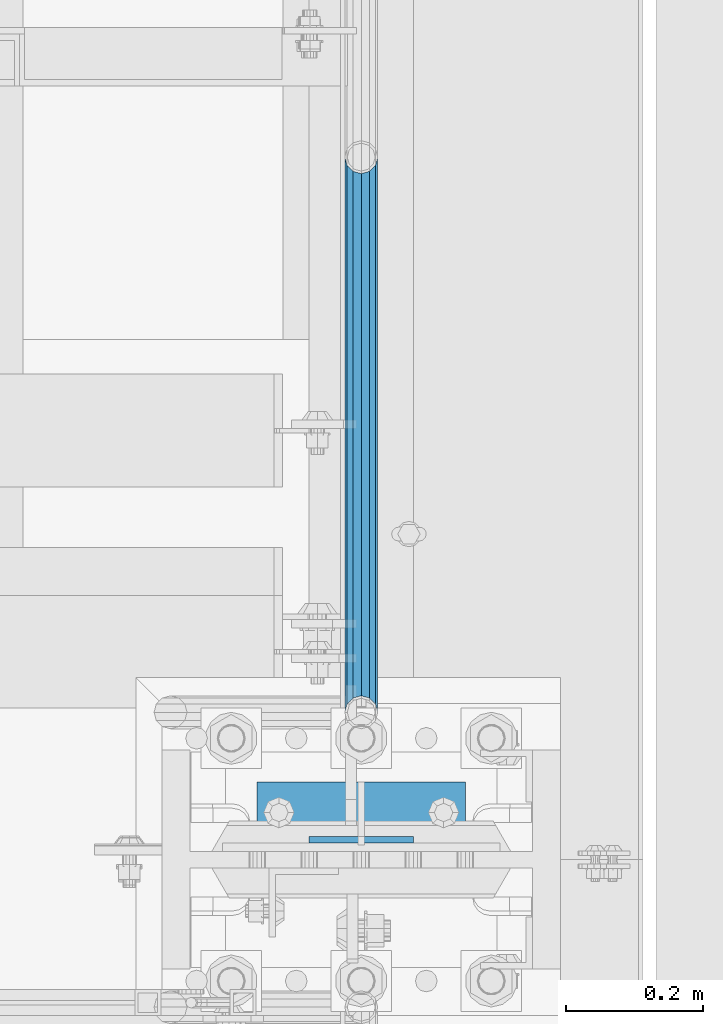
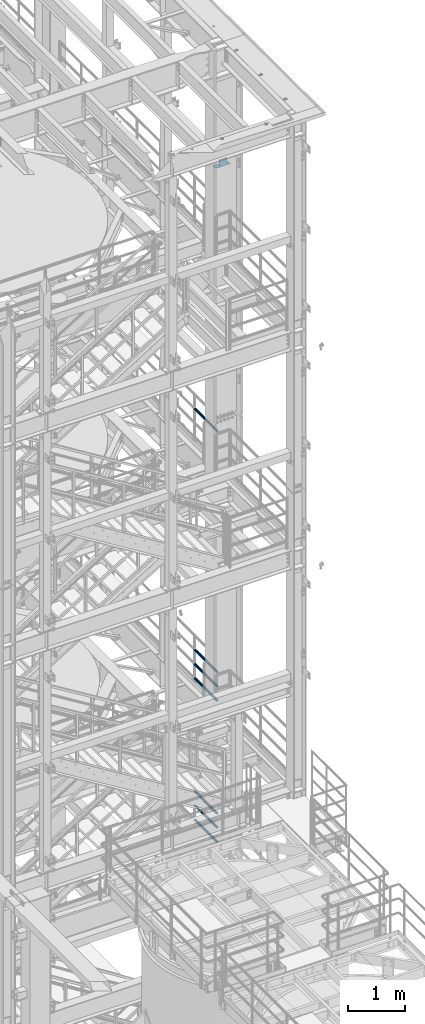
# One storey, part 1219 of 1876: 9 beams, 4 elements without a shape of their own.
"""IFC2X3 building model written with IfcOpenShell, lengths in millimetres."""

from ifc_helpers import new_model, si_unit, frame, origin_with_axes, place, context, subcontext, project, spatial, faceted_brep, material, type_object, element, aggregate, save


model = new_model("IFC2X3")

# Units and contexts
model_context = context("Model", 3, precision=1e-05, world=origin_with_axes())
body_context = subcontext(model_context, "Body", "Model", "MODEL_VIEW")
ifc_project = project(units=[si_unit("LENGTHUNIT", "METRE", prefix="MILLI"), si_unit("AREAUNIT", "SQUARE_METRE"), si_unit("VOLUMEUNIT", "CUBIC_METRE"), si_unit("MASSUNIT", "GRAM", prefix="KILO"), si_unit("TIMEUNIT", "SECOND"), si_unit("PLANEANGLEUNIT", "RADIAN"), si_unit("SOLIDANGLEUNIT", "STERADIAN"), si_unit("THERMODYNAMICTEMPERATUREUNIT", "DEGREE_CELSIUS"), si_unit("LUMINOUSINTENSITYUNIT", "LUMEN")], contexts=[model_context])

# Site, building, storey
site_placement = place(None, origin_with_axes())
site = spatial("IfcSite", under=ifc_project, at=site_placement, CompositionType="ELEMENT")
building_placement = place(site_placement, origin_with_axes())
building = spatial("IfcBuilding", under=site, at=building_placement, Name="Undefined", CompositionType="ELEMENT")
storey_placement = place(building_placement, origin_with_axes())
storey = spatial("IfcBuildingStorey", under=building, at=storey_placement, Name="Undefined", CompositionType="ELEMENT", Elevation=0.0)

# Assembly, beam
assembly_1_placement = place(storey_placement, origin_with_axes())
assembly_1 = element("IfcElementAssembly", 1, at=assembly_1_placement, inside=storey, Name="BEAM", AssemblyPlace="NOTDEFINED", PredefinedType="RIGID_FRAME")
ifc_material_1 = material(Name="STEEL/A36")
beam_type_1 = type_object("IfcBeamType", PredefinedType="NOTDEFINED")
beam_1_placement = place(assembly_1_placement, frame((7696.2, -4542.63125, 19958.05), z_axis=(0.0, 0.0, 1.0), x_axis=(-1.0, 0.0, 0.0)))
beam_1 = element("IfcBeam", 2, at=beam_1_placement, type_object=beam_type_1, material=ifc_material_1, Name="PLATE", context=body_context, shape_type="Brep", body=[
    faceted_brep([(0.0, 4.76249999999982, -76.1999999999998), (3.63797880709171e-12, 4.76249999999982, 76.1999969482422), (152.399993896484, 4.76250000000073, 76.1999969482422), (152.4, 4.76249999999982, -76.1999999999998), (3.63797880709171e-12, -4.76249999999982, 76.1999969482422), (152.399993896484, -4.76250000000073, 76.1999969482422), (0.0, -4.76249999999982, -76.1999999999998), (152.4, -4.76249999999982, -76.1999999999998)], [[[0, 1, 2, 3]], [[4, 5, 2, 1]], [[4, 6, 7, 5]], [[6, 0, 3, 7]], [[5, 7, 3, 2]], [[6, 4, 1, 0]]]),
])

assembly_2_placement = place(storey_placement, origin_with_axes())
assembly_2 = element("IfcElementAssembly", 3, at=assembly_2_placement, inside=storey, Name="RAIL", AssemblyPlace="NOTDEFINED", PredefinedType="RIGID_FRAME")
ifc_material_2 = material()
beam_type_2 = type_object("IfcBeamType", Name="PIPE1-1/2SCH40", PredefinedType="NOTDEFINED")
beam_2_placement = place(assembly_2_placement, frame((7620.00000000001, -4356.1, 14081.1250000359), z_axis=(0.0, 0.0, -1.0), x_axis=(0.0, 1.0, 0.0)))
beam_2 = element("IfcBeam", 4, at=beam_2_placement, type_object=beam_type_2, material=ifc_material_2, Name="RAIL", ObjectType="PIPE1-1/2SCH40", context=body_context, shape_type="Brep", body=[
    faceted_brep([(0.0, 24.1299999999992, 0.0), (12.0650000000064, 20.8971929933177, -12.0649999999987), (12.0650000000064, 20.8971929933177, 12.0649999999987), (12.0650000000064, -20.8971929933177, 12.0649999999987), (12.0650000000064, -20.8971929933177, -12.0649999999987), (0.0, -24.1299999999992, 0.0), (20.8971929933249, -12.0650000000005, 20.8971929933177), (20.8971929933249, -12.0650000000005, 15.8661214311796), (15.2545715621445, -17.7076214311801, 10.2235000000001), (12.5151929933249, -20.4470000000001, 0.0), (15.2545715621445, -17.7076214311801, -10.2235000000001), (20.8971929933249, -12.0650000000005, -15.8661214311796), (20.8971929933249, -12.0650000000005, -20.8971929933177), (24.1300000000063, 0.0, -20.4470000000001), (24.1300000000063, 0.0, -24.130000000001), (21.3906214311868, -10.2235000000001, -17.7076214311819), (21.3906214311868, 10.2235000000001, -17.7076214311819), (20.8971929933249, 12.0650000000005, -15.8661214311796), (20.8971929933249, 12.0650000000005, -20.8971929933177), (15.2545715621445, 17.7076214311801, -10.2235000000001), (12.5151929933249, 20.4470000000001, 0.0), (15.2545715621445, 17.7076214311801, 10.2235000000001), (20.8971929933249, 12.0650000000005, 15.8661214311796), (20.8971929933249, 12.0650000000005, 20.8971929933177), (21.3906214311868, 10.2235000000001, 17.7076214311819), (24.1300000000064, 0.0, 20.4470000000001), (24.1300000000064, 0.0, 24.130000000001), (21.3906214311868, -10.2235000000001, 17.7076214311819), (813.396900000002, 24.1300000000001, 0.0), (801.331900000001, 20.8971929933186, -12.0649999999987), (792.499707006684, 12.0649999999996, -20.8971929933177), (813.396900000002, -24.1300000000319, 0.0), (801.331900000001, -20.8971929933186, -12.0649999999987), (801.331900000001, -20.8971929933186, 12.0649999999987), (792.499707006684, -12.0649999999996, 20.8971929933177), (792.499707006684, -12.0649999999996, -20.8971929933177), (789.266900000001, 0.0, -24.130000000001), (792.00627856883, 10.2235000000001, -17.7076214311819), (789.266900000001, 0.0, -20.4470000000001), (792.499707006684, 12.0649999999678, -15.8661214312124), (792.499707006684, -12.0650000000314, -15.8661214311469), (792.006278568813, -10.2235000000001, -17.7076214311819), (798.142328437831, -17.7076214311801, -10.2235000000001), (800.881707006651, -20.4470000000001, 0.0), (798.142328437831, -17.7076214311801, 10.2235000000001), (792.499707006684, -12.0650000000314, 15.8661214311469), (792.006278568813, -10.2235000000001, 17.7076214311819), (789.266900000001, -9.09494701772928e-13, 20.4470000000001), (789.266900000001, -9.09494701772928e-13, 24.130000000001), (792.499707006684, 12.0649999999996, 20.8971929933177), (801.331900000001, 20.8971929933186, 12.0649999999987), (792.499707006684, 12.0649999999678, 15.8661214312124), (798.142328437896, 17.7076214311801, 10.2235000000001), (800.881707006714, 20.4470000000001, 0.0), (798.142328437896, 17.7076214311801, -10.2235000000001), (792.00627856883, 10.2235000000001, 17.7076214311819)], [[[0, 1, 2]], [[3, 4, 5]], [[6, 7, 8, 9, 10, 11, 12, 4, 3]], [[13, 14, 12, 11, 15]], [[16, 17, 18, 14, 13]], [[2, 1, 18, 17, 19, 20, 21, 22, 23]], [[23, 22, 24, 25, 26]], [[26, 25, 27, 7, 6]], [[1, 0, 28, 29]], [[18, 1, 29, 30]], [[31, 32, 33]], [[6, 3, 33, 34]], [[3, 5, 31, 33]], [[5, 4, 32, 31]], [[4, 12, 35, 32]], [[12, 14, 36, 35]], [[14, 18, 30, 36]], [[37, 38, 36, 30, 39]], [[40, 35, 36, 38, 41]], [[33, 32, 35, 40, 42, 43, 44, 45, 34]], [[34, 45, 46, 47, 48]], [[26, 6, 34, 48]], [[2, 23, 49, 50]], [[23, 26, 48, 49]], [[0, 2, 50, 28]], [[28, 50, 29]], [[49, 51, 52, 53, 54, 39, 30, 29, 50]], [[48, 47, 55, 51, 49]], [[25, 24, 55, 47]], [[55, 24, 22, 21, 52, 51]], [[21, 20, 53, 52]], [[20, 19, 54, 53]], [[19, 17, 16, 37, 39, 54]], [[16, 13, 38, 37]], [[13, 15, 41, 38]], [[41, 15, 11, 10, 42, 40]], [[10, 9, 43, 42]], [[9, 8, 44, 43]], [[8, 7, 27, 46, 45, 44]], [[27, 25, 47, 46]]]),
])
aggregate(assembly_2, [beam_2])

# Assembly, beams
assembly_3_placement = place(storey_placement, origin_with_axes())
assembly_3 = element("IfcElementAssembly", 5, at=assembly_3_placement, inside=storey, Name="RAIL", AssemblyPlace="NOTDEFINED", PredefinedType="RIGID_FRAME")
beam_3_placement = place(assembly_3_placement, frame((7620.00000000001, -3542.7031, 8315.325), z_axis=(0.0, 0.0, 1.0), x_axis=(0.0, -1.0, 0.0)))
beam_3 = element("IfcBeam", 6, at=beam_3_placement, type_object=beam_type_2, material=ifc_material_2, Name="RAIL", ObjectType="PIPE1-1/2SCH40", context=body_context, shape_type="Brep", body=[
    faceted_brep([(792.499707006684, -12.0649999999996, 20.8971929933177), (792.499707006684, -12.0650000000314, 15.8661214311469), (792.006278568813, -10.2235000000001, 17.7076214311819), (789.266900000001, -9.09494701772928e-13, 20.4470000000001), (789.266900000001, -9.09494701772928e-13, 24.130000000001), (792.00627856883, 10.2235000000001, 17.7076214311819), (792.499707006684, 12.0649999999678, 15.8661214312124), (792.499707006684, 12.0649999999996, 20.8971929933177), (813.396900000002, 24.1300000000001, 0.0), (801.331900000001, 20.8971929933186, 12.0649999999987), (801.331900000001, 20.8971929933186, -12.0649999999987), (798.142328437896, 17.7076214311801, 10.2235000000001), (800.881707006714, 20.4470000000001, 0.0), (798.142328437896, 17.7076214311801, -10.2235000000001), (792.499707006684, 12.0649999999678, -15.8661214312124), (792.499707006684, 12.0649999999996, -20.8971929933177), (792.00627856883, 10.2235000000001, -17.7076214311819), (789.266900000001, 0.0, -20.4470000000001), (789.266900000001, 0.0, -24.130000000001), (792.499707006684, -12.0650000000314, -15.8661214311469), (792.499707006684, -12.0649999999996, -20.8971929933177), (792.006278568813, -10.2235000000001, -17.7076214311819), (813.396900000002, -24.1300000000319, 0.0), (801.331900000001, -20.8971929933186, -12.0649999999987), (801.331900000001, -20.8971929933186, 12.0649999999987), (798.142328437831, -17.7076214311801, -10.2235000000001), (800.881707006651, -20.4470000000001, 0.0), (798.142328437831, -17.7076214311801, 10.2235000000001), (12.0650000000064, -20.8971929933177, -12.0649999999987), (20.8971929933249, -12.0650000000005, -20.8971929933177), (0.0, 24.1299999999992, 0.0), (12.0650000000064, 20.8971929933177, -12.0649999999987), (12.0650000000064, 20.8971929933177, 12.0649999999987), (20.8971929933249, 12.0650000000005, 20.8971929933177), (24.1300000000064, 0.0, 24.130000000001), (20.8971929933249, 12.0650000000005, -20.8971929933177), (24.1300000000063, 0.0, -24.130000000001), (24.1300000000063, 0.0, -20.4470000000001), (20.8971929933249, -12.0650000000005, -15.8661214311796), (21.3906214311868, -10.2235000000001, -17.7076214311819), (21.3906214311868, 10.2235000000001, -17.7076214311819), (20.8971929933249, 12.0650000000005, -15.8661214311796), (15.2545715621445, 17.7076214311801, -10.2235000000001), (12.5151929933249, 20.4470000000001, 0.0), (15.2545715621445, 17.7076214311801, 10.2235000000001), (20.8971929933249, 12.0650000000005, 15.8661214311796), (21.3906214311868, 10.2235000000001, 17.7076214311819), (24.1300000000064, 0.0, 20.4470000000001), (21.3906214311868, -10.2235000000001, 17.7076214311819), (20.8971929933249, -12.0650000000005, 15.8661214311796), (20.8971929933249, -12.0650000000005, 20.8971929933177), (12.0650000000064, -20.8971929933177, 12.0649999999987), (0.0, -24.1299999999992, 0.0), (15.2545715621445, -17.7076214311801, 10.2235000000001), (12.5151929933249, -20.4470000000001, 0.0), (15.2545715621445, -17.7076214311801, -10.2235000000001)], [[[0, 1, 2, 3, 4]], [[4, 3, 5, 6, 7]], [[8, 9, 10]], [[7, 6, 11, 12, 13, 14, 15, 10, 9]], [[16, 17, 18, 15, 14]], [[19, 20, 18, 17, 21]], [[22, 23, 24]], [[24, 23, 20, 19, 25, 26, 27, 1, 0]], [[28, 29, 20, 23]], [[30, 31, 32]], [[33, 34, 4, 7]], [[32, 33, 7, 9]], [[30, 32, 9, 8]], [[31, 30, 8, 10]], [[35, 31, 10, 15]], [[36, 35, 15, 18]], [[29, 36, 18, 20]], [[37, 36, 29, 38, 39]], [[40, 41, 35, 36, 37]], [[32, 31, 35, 41, 42, 43, 44, 45, 33]], [[33, 45, 46, 47, 34]], [[34, 47, 48, 49, 50]], [[34, 50, 0, 4]], [[50, 51, 24, 0]], [[51, 52, 22, 24]], [[52, 28, 23, 22]], [[51, 28, 52]], [[50, 49, 53, 54, 55, 38, 29, 28, 51]], [[55, 54, 26, 25]], [[21, 39, 38, 55, 25, 19]], [[37, 39, 21, 17]], [[40, 37, 17, 16]], [[42, 41, 40, 16, 14, 13]], [[43, 42, 13, 12]], [[44, 43, 12, 11]], [[5, 46, 45, 44, 11, 6]], [[47, 46, 5, 3]], [[48, 47, 3, 2]], [[53, 49, 48, 2, 1, 27]], [[54, 53, 27, 26]]]),
])
beam_4_placement = place(assembly_3_placement, frame((7620.00000000001, -4356.1, 8620.125000036), z_axis=(0.0, 0.0, -1.0), x_axis=(0.0, 1.0, 0.0)))
beam_4 = element("IfcBeam", 7, at=beam_4_placement, type_object=beam_type_2, material=ifc_material_2, Name="RAIL", ObjectType="PIPE1-1/2SCH40", context=body_context, shape_type="Brep", body=[
    faceted_brep([(0.0, 24.1299999999992, 0.0), (12.0650000000064, 20.8971929933177, -12.0649999999987), (12.0650000000064, 20.8971929933177, 12.0649999999987), (12.0650000000064, -20.8971929933177, 12.0649999999987), (12.0650000000064, -20.8971929933177, -12.0649999999987), (0.0, -24.1299999999992, 0.0), (20.8971929933249, -12.0650000000005, 20.8971929933177), (20.8971929933249, -12.0650000000005, 15.8661214311796), (15.2545715621445, -17.7076214311801, 10.2235000000001), (12.5151929933249, -20.4470000000001, 0.0), (15.2545715621445, -17.7076214311801, -10.2235000000001), (20.8971929933249, -12.0650000000005, -15.8661214311796), (20.8971929933249, -12.0650000000005, -20.8971929933177), (24.1300000000063, 0.0, -20.4470000000001), (24.1300000000063, 0.0, -24.130000000001), (21.3906214311868, -10.2235000000001, -17.7076214311819), (21.3906214311868, 10.2235000000001, -17.7076214311819), (20.8971929933249, 12.0650000000005, -15.8661214311796), (20.8971929933249, 12.0650000000005, -20.8971929933177), (15.2545715621445, 17.7076214311801, -10.2235000000001), (12.5151929933249, 20.4470000000001, 0.0), (15.2545715621445, 17.7076214311801, 10.2235000000001), (20.8971929933249, 12.0650000000005, 15.8661214311796), (20.8971929933249, 12.0650000000005, 20.8971929933177), (21.3906214311868, 10.2235000000001, 17.7076214311819), (24.1300000000064, 0.0, 20.4470000000001), (24.1300000000064, 0.0, 24.130000000001), (21.3906214311868, -10.2235000000001, 17.7076214311819), (813.396900000002, 24.1300000000001, 0.0), (801.331900000001, 20.8971929933186, -12.0649999999987), (792.499707006684, 12.0649999999996, -20.8971929933177), (813.396900000002, -24.1300000000319, 0.0), (801.331900000001, -20.8971929933186, -12.0649999999987), (801.331900000001, -20.8971929933186, 12.0649999999987), (792.499707006684, -12.0649999999996, 20.8971929933177), (792.499707006684, -12.0649999999996, -20.8971929933177), (789.266900000001, 0.0, -24.130000000001), (792.00627856883, 10.2235000000001, -17.7076214311819), (789.266900000001, 0.0, -20.4470000000001), (792.499707006684, 12.0649999999678, -15.8661214312124), (792.499707006684, -12.0650000000314, -15.8661214311469), (792.006278568813, -10.2235000000001, -17.7076214311819), (798.142328437831, -17.7076214311801, -10.2235000000001), (800.881707006651, -20.4470000000001, 0.0), (798.142328437831, -17.7076214311801, 10.2235000000001), (792.499707006684, -12.0650000000314, 15.8661214311469), (792.006278568813, -10.2235000000001, 17.7076214311819), (789.266900000001, -9.09494701772928e-13, 20.4470000000001), (789.266900000001, -9.09494701772928e-13, 24.130000000001), (792.499707006684, 12.0649999999996, 20.8971929933177), (801.331900000001, 20.8971929933186, 12.0649999999987), (792.499707006684, 12.0649999999678, 15.8661214312124), (798.142328437896, 17.7076214311801, 10.2235000000001), (800.881707006714, 20.4470000000001, 0.0), (798.142328437896, 17.7076214311801, -10.2235000000001), (792.00627856883, 10.2235000000001, 17.7076214311819)], [[[0, 1, 2]], [[3, 4, 5]], [[6, 7, 8, 9, 10, 11, 12, 4, 3]], [[13, 14, 12, 11, 15]], [[16, 17, 18, 14, 13]], [[2, 1, 18, 17, 19, 20, 21, 22, 23]], [[23, 22, 24, 25, 26]], [[26, 25, 27, 7, 6]], [[1, 0, 28, 29]], [[18, 1, 29, 30]], [[31, 32, 33]], [[6, 3, 33, 34]], [[3, 5, 31, 33]], [[5, 4, 32, 31]], [[4, 12, 35, 32]], [[12, 14, 36, 35]], [[14, 18, 30, 36]], [[37, 38, 36, 30, 39]], [[40, 35, 36, 38, 41]], [[33, 32, 35, 40, 42, 43, 44, 45, 34]], [[34, 45, 46, 47, 48]], [[26, 6, 34, 48]], [[2, 23, 49, 50]], [[23, 26, 48, 49]], [[0, 2, 50, 28]], [[28, 50, 29]], [[49, 51, 52, 53, 54, 39, 30, 29, 50]], [[48, 47, 55, 51, 49]], [[25, 24, 55, 47]], [[55, 24, 22, 21, 52, 51]], [[21, 20, 53, 52]], [[20, 19, 54, 53]], [[19, 17, 16, 37, 39, 54]], [[16, 13, 38, 37]], [[13, 15, 41, 38]], [[41, 15, 11, 10, 42, 40]], [[10, 9, 43, 42]], [[9, 8, 44, 43]], [[8, 7, 27, 46, 45, 44]], [[27, 25, 47, 46]]]),
])
beam_5_placement = place(assembly_3_placement, frame((7620.00000000001, -4356.1, 8924.92500003594), z_axis=(0.0, 0.0, -1.0), x_axis=(0.0, 1.0, 0.0)))
beam_5 = element("IfcBeam", 8, at=beam_5_placement, type_object=beam_type_2, material=ifc_material_2, Name="RAIL", ObjectType="PIPE1-1/2SCH40", context=body_context, shape_type="Brep", body=[
    faceted_brep([(0.0, 24.1299999999992, 0.0), (12.0650000000064, 20.8971929933177, -12.0649999999987), (12.0650000000064, 20.8971929933177, 12.0649999999987), (12.0650000000064, -20.8971929933177, 12.0649999999987), (12.0650000000064, -20.8971929933177, -12.0649999999987), (0.0, -24.1299999999992, 0.0), (20.8971929933249, -12.0650000000005, 20.8971929933177), (20.8971929933249, -12.0650000000005, 15.8661214311796), (15.2545715621445, -17.7076214311801, 10.2235000000001), (12.5151929933249, -20.4470000000001, 0.0), (15.2545715621445, -17.7076214311801, -10.2235000000001), (20.8971929933249, -12.0650000000005, -15.8661214311796), (20.8971929933249, -12.0650000000005, -20.8971929933177), (24.1300000000063, 0.0, -20.4470000000001), (24.1300000000063, 0.0, -24.130000000001), (21.3906214311868, -10.2235000000001, -17.7076214311819), (21.3906214311868, 10.2235000000001, -17.7076214311819), (20.8971929933249, 12.0650000000005, -15.8661214311796), (20.8971929933249, 12.0650000000005, -20.8971929933177), (15.2545715621445, 17.7076214311801, -10.2235000000001), (12.5151929933249, 20.4470000000001, 0.0), (15.2545715621445, 17.7076214311801, 10.2235000000001), (20.8971929933249, 12.0650000000005, 15.8661214311796), (20.8971929933249, 12.0650000000005, 20.8971929933177), (21.3906214311868, 10.2235000000001, 17.7076214311819), (24.1300000000064, 0.0, 20.4470000000001), (24.1300000000064, 0.0, 24.130000000001), (21.3906214311868, -10.2235000000001, 17.7076214311819), (813.396900000002, 24.1300000000001, 0.0), (801.331900000001, 20.8971929933186, -12.0649999999987), (792.499707006684, 12.0649999999996, -20.8971929933177), (813.396900000002, -24.1300000000319, 0.0), (801.331900000001, -20.8971929933186, -12.0649999999987), (801.331900000001, -20.8971929933186, 12.0649999999987), (792.499707006684, -12.0649999999996, 20.8971929933177), (792.499707006684, -12.0649999999996, -20.8971929933177), (789.266900000001, 0.0, -24.130000000001), (792.00627856883, 10.2235000000001, -17.7076214311819), (789.266900000001, 0.0, -20.4470000000001), (792.499707006684, 12.0649999999678, -15.8661214312124), (792.499707006684, -12.0650000000314, -15.8661214311469), (792.006278568813, -10.2235000000001, -17.7076214311819), (798.142328437831, -17.7076214311801, -10.2235000000001), (800.881707006651, -20.4470000000001, 0.0), (798.142328437831, -17.7076214311801, 10.2235000000001), (792.499707006684, -12.0650000000314, 15.8661214311469), (792.006278568813, -10.2235000000001, 17.7076214311819), (789.266900000001, -9.09494701772928e-13, 20.4470000000001), (789.266900000001, -9.09494701772928e-13, 24.130000000001), (792.499707006684, 12.0649999999996, 20.8971929933177), (801.331900000001, 20.8971929933186, 12.0649999999987), (792.499707006684, 12.0649999999678, 15.8661214312124), (798.142328437896, 17.7076214311801, 10.2235000000001), (800.881707006714, 20.4470000000001, 0.0), (798.142328437896, 17.7076214311801, -10.2235000000001), (792.00627856883, 10.2235000000001, 17.7076214311819)], [[[0, 1, 2]], [[3, 4, 5]], [[6, 7, 8, 9, 10, 11, 12, 4, 3]], [[13, 14, 12, 11, 15]], [[16, 17, 18, 14, 13]], [[2, 1, 18, 17, 19, 20, 21, 22, 23]], [[23, 22, 24, 25, 26]], [[26, 25, 27, 7, 6]], [[1, 0, 28, 29]], [[18, 1, 29, 30]], [[31, 32, 33]], [[6, 3, 33, 34]], [[3, 5, 31, 33]], [[5, 4, 32, 31]], [[4, 12, 35, 32]], [[12, 14, 36, 35]], [[14, 18, 30, 36]], [[37, 38, 36, 30, 39]], [[40, 35, 36, 38, 41]], [[33, 32, 35, 40, 42, 43, 44, 45, 34]], [[34, 45, 46, 47, 48]], [[26, 6, 34, 48]], [[2, 23, 49, 50]], [[23, 26, 48, 49]], [[0, 2, 50, 28]], [[28, 50, 29]], [[49, 51, 52, 53, 54, 39, 30, 29, 50]], [[48, 47, 55, 51, 49]], [[25, 24, 55, 47]], [[55, 24, 22, 21, 52, 51]], [[21, 20, 53, 52]], [[20, 19, 54, 53]], [[19, 17, 16, 37, 39, 54]], [[16, 13, 38, 37]], [[13, 15, 41, 38]], [[41, 15, 11, 10, 42, 40]], [[10, 9, 43, 42]], [[9, 8, 44, 43]], [[8, 7, 27, 46, 45, 44]], [[27, 25, 47, 46]]]),
])
aggregate(assembly_3, [beam_3, beam_4, beam_5])

assembly_4_placement = place(storey_placement, origin_with_axes())
assembly_4 = element("IfcElementAssembly", 9, at=assembly_4_placement, inside=storey, Name="RAIL", AssemblyPlace="NOTDEFINED", PredefinedType="RIGID_FRAME")
beam_6_placement = place(assembly_4_placement, frame((7620.00000000001, -3542.70310000001, 5292.725), z_axis=(0.0, 0.0, 1.0), x_axis=(0.0, -1.0, 0.0)))
beam_6 = element("IfcBeam", 10, at=beam_6_placement, type_object=beam_type_2, material=ifc_material_2, Name="RAIL", ObjectType="PIPE1-1/2SCH40", context=body_context, shape_type="Brep", body=[
    faceted_brep([(792.499707006684, -12.0649999999996, 20.8971929933177), (792.499707006684, -12.0650000000314, 15.8661214311469), (792.006278568813, -10.2235000000001, 17.7076214311819), (789.266900000001, -9.09494701772928e-13, 20.4470000000001), (789.266900000001, -9.09494701772928e-13, 24.130000000001), (792.00627856883, 10.2235000000001, 17.7076214311819), (792.499707006684, 12.0649999999678, 15.8661214312124), (792.499707006684, 12.0649999999996, 20.8971929933177), (813.396900000002, 24.1300000000001, 0.0), (801.331900000001, 20.8971929933186, 12.0649999999987), (801.331900000001, 20.8971929933186, -12.0649999999987), (798.142328437896, 17.7076214311801, 10.2235000000001), (800.881707006714, 20.4470000000001, 0.0), (798.142328437896, 17.7076214311801, -10.2235000000001), (792.499707006684, 12.0649999999678, -15.8661214312124), (792.499707006684, 12.0649999999996, -20.8971929933177), (792.00627856883, 10.2235000000001, -17.7076214311819), (789.266900000001, 0.0, -20.4470000000001), (789.266900000001, 0.0, -24.130000000001), (792.499707006684, -12.0650000000314, -15.8661214311469), (792.499707006684, -12.0649999999996, -20.8971929933177), (792.006278568813, -10.2235000000001, -17.7076214311819), (813.396900000002, -24.1300000000319, 0.0), (801.331900000001, -20.8971929933186, -12.0649999999987), (801.331900000001, -20.8971929933186, 12.0649999999987), (798.142328437831, -17.7076214311801, -10.2235000000001), (800.881707006651, -20.4470000000001, 0.0), (798.142328437831, -17.7076214311801, 10.2235000000001), (12.0650000000064, -20.8971929933177, -12.0649999999987), (20.8971929933249, -12.0650000000005, -20.8971929933177), (0.0, 24.1299999999992, 0.0), (12.0650000000064, 20.8971929933177, -12.0649999999987), (12.0650000000064, 20.8971929933177, 12.0649999999987), (20.8971929933249, 12.0650000000005, 20.8971929933177), (24.1300000000064, 0.0, 24.130000000001), (20.8971929933249, 12.0650000000005, -20.8971929933177), (24.1300000000063, 0.0, -24.130000000001), (24.1300000000063, 0.0, -20.4470000000001), (20.8971929933249, -12.0650000000005, -15.8661214311796), (21.3906214311868, -10.2235000000001, -17.7076214311819), (21.3906214311868, 10.2235000000001, -17.7076214311819), (20.8971929933249, 12.0650000000005, -15.8661214311796), (15.2545715621445, 17.7076214311801, -10.2235000000001), (12.5151929933249, 20.4470000000001, 0.0), (15.2545715621445, 17.7076214311801, 10.2235000000001), (20.8971929933249, 12.0650000000005, 15.8661214311796), (21.3906214311868, 10.2235000000001, 17.7076214311819), (24.1300000000064, 0.0, 20.4470000000001), (21.3906214311868, -10.2235000000001, 17.7076214311819), (20.8971929933249, -12.0650000000005, 15.8661214311796), (20.8971929933249, -12.0650000000005, 20.8971929933177), (12.0650000000064, -20.8971929933177, 12.0649999999987), (0.0, -24.1299999999992, 0.0), (15.2545715621445, -17.7076214311801, 10.2235000000001), (12.5151929933249, -20.4470000000001, 0.0), (15.2545715621445, -17.7076214311801, -10.2235000000001)], [[[0, 1, 2, 3, 4]], [[4, 3, 5, 6, 7]], [[8, 9, 10]], [[7, 6, 11, 12, 13, 14, 15, 10, 9]], [[16, 17, 18, 15, 14]], [[19, 20, 18, 17, 21]], [[22, 23, 24]], [[24, 23, 20, 19, 25, 26, 27, 1, 0]], [[28, 29, 20, 23]], [[30, 31, 32]], [[33, 34, 4, 7]], [[32, 33, 7, 9]], [[30, 32, 9, 8]], [[31, 30, 8, 10]], [[35, 31, 10, 15]], [[36, 35, 15, 18]], [[29, 36, 18, 20]], [[37, 36, 29, 38, 39]], [[40, 41, 35, 36, 37]], [[32, 31, 35, 41, 42, 43, 44, 45, 33]], [[33, 45, 46, 47, 34]], [[34, 47, 48, 49, 50]], [[34, 50, 0, 4]], [[50, 51, 24, 0]], [[51, 52, 22, 24]], [[52, 28, 23, 22]], [[51, 28, 52]], [[50, 49, 53, 54, 55, 38, 29, 28, 51]], [[55, 54, 26, 25]], [[21, 39, 38, 55, 25, 19]], [[37, 39, 21, 17]], [[40, 37, 17, 16]], [[42, 41, 40, 16, 14, 13]], [[43, 42, 13, 12]], [[44, 43, 12, 11]], [[5, 46, 45, 44, 11, 6]], [[47, 46, 5, 3]], [[48, 47, 3, 2]], [[53, 49, 48, 2, 1, 27]], [[54, 53, 27, 26]]]),
])
beam_7_placement = place(assembly_4_placement, frame((7620.00000000001, -4356.1, 5597.525000036), z_axis=(0.0, 0.0, -1.0), x_axis=(0.0, 1.0, 0.0)))
beam_7 = element("IfcBeam", 11, at=beam_7_placement, type_object=beam_type_2, material=ifc_material_2, Name="RAIL", ObjectType="PIPE1-1/2SCH40", context=body_context, shape_type="Brep", body=[
    faceted_brep([(0.0, 24.1299999999992, 0.0), (12.0650000000064, 20.8971929933177, -12.0649999999987), (12.0650000000064, 20.8971929933177, 12.0649999999987), (12.0650000000064, -20.8971929933177, 12.0649999999987), (12.0650000000064, -20.8971929933177, -12.0649999999987), (0.0, -24.1299999999992, 0.0), (20.8971929933249, -12.0650000000005, 20.8971929933177), (20.8971929933249, -12.0650000000005, 15.8661214311796), (15.2545715621445, -17.7076214311801, 10.2235000000001), (12.5151929933249, -20.4470000000001, 0.0), (15.2545715621445, -17.7076214311801, -10.2235000000001), (20.8971929933249, -12.0650000000005, -15.8661214311796), (20.8971929933249, -12.0650000000005, -20.8971929933177), (24.1300000000063, 0.0, -20.4470000000001), (24.1300000000063, 0.0, -24.130000000001), (21.3906214311868, -10.2235000000001, -17.7076214311819), (21.3906214311868, 10.2235000000001, -17.7076214311819), (20.8971929933249, 12.0650000000005, -15.8661214311796), (20.8971929933249, 12.0650000000005, -20.8971929933177), (15.2545715621445, 17.7076214311801, -10.2235000000001), (12.5151929933249, 20.4470000000001, 0.0), (15.2545715621445, 17.7076214311801, 10.2235000000001), (20.8971929933249, 12.0650000000005, 15.8661214311796), (20.8971929933249, 12.0650000000005, 20.8971929933177), (21.3906214311868, 10.2235000000001, 17.7076214311819), (24.1300000000064, 0.0, 20.4470000000001), (24.1300000000064, 0.0, 24.130000000001), (21.3906214311868, -10.2235000000001, 17.7076214311819), (813.396900000002, 24.1300000000001, 0.0), (801.331900000001, 20.8971929933186, -12.0649999999987), (792.499707006684, 12.0649999999996, -20.8971929933177), (813.396900000002, -24.1300000000319, 0.0), (801.331900000001, -20.8971929933186, -12.0649999999987), (801.331900000001, -20.8971929933186, 12.0649999999987), (792.499707006684, -12.0649999999996, 20.8971929933177), (792.499707006684, -12.0649999999996, -20.8971929933177), (789.266900000001, 0.0, -24.130000000001), (792.00627856883, 10.2235000000001, -17.7076214311819), (789.266900000001, 0.0, -20.4470000000001), (792.499707006684, 12.0649999999678, -15.8661214312124), (792.499707006684, -12.0650000000314, -15.8661214311469), (792.006278568813, -10.2235000000001, -17.7076214311819), (798.142328437831, -17.7076214311801, -10.2235000000001), (800.881707006651, -20.4470000000001, 0.0), (798.142328437831, -17.7076214311801, 10.2235000000001), (792.499707006684, -12.0650000000314, 15.8661214311469), (792.006278568813, -10.2235000000001, 17.7076214311819), (789.266900000001, -9.09494701772928e-13, 20.4470000000001), (789.266900000001, -9.09494701772928e-13, 24.130000000001), (792.499707006684, 12.0649999999996, 20.8971929933177), (801.331900000001, 20.8971929933186, 12.0649999999987), (792.499707006684, 12.0649999999678, 15.8661214312124), (798.142328437896, 17.7076214311801, 10.2235000000001), (800.881707006714, 20.4470000000001, 0.0), (798.142328437896, 17.7076214311801, -10.2235000000001), (792.00627856883, 10.2235000000001, 17.7076214311819)], [[[0, 1, 2]], [[3, 4, 5]], [[6, 7, 8, 9, 10, 11, 12, 4, 3]], [[13, 14, 12, 11, 15]], [[16, 17, 18, 14, 13]], [[2, 1, 18, 17, 19, 20, 21, 22, 23]], [[23, 22, 24, 25, 26]], [[26, 25, 27, 7, 6]], [[1, 0, 28, 29]], [[18, 1, 29, 30]], [[31, 32, 33]], [[6, 3, 33, 34]], [[3, 5, 31, 33]], [[5, 4, 32, 31]], [[4, 12, 35, 32]], [[12, 14, 36, 35]], [[14, 18, 30, 36]], [[37, 38, 36, 30, 39]], [[40, 35, 36, 38, 41]], [[33, 32, 35, 40, 42, 43, 44, 45, 34]], [[34, 45, 46, 47, 48]], [[26, 6, 34, 48]], [[2, 23, 49, 50]], [[23, 26, 48, 49]], [[0, 2, 50, 28]], [[28, 50, 29]], [[49, 51, 52, 53, 54, 39, 30, 29, 50]], [[48, 47, 55, 51, 49]], [[25, 24, 55, 47]], [[55, 24, 22, 21, 52, 51]], [[21, 20, 53, 52]], [[20, 19, 54, 53]], [[19, 17, 16, 37, 39, 54]], [[16, 13, 38, 37]], [[13, 15, 41, 38]], [[41, 15, 11, 10, 42, 40]], [[10, 9, 43, 42]], [[9, 8, 44, 43]], [[8, 7, 27, 46, 45, 44]], [[27, 25, 47, 46]]]),
])
beam_8_placement = place(assembly_4_placement, frame((7620.00000000001, -4356.1, 5902.32500003594), z_axis=(0.0, 0.0, -1.0), x_axis=(0.0, 1.0, 0.0)))
beam_8 = element("IfcBeam", 12, at=beam_8_placement, type_object=beam_type_2, material=ifc_material_2, Name="RAIL", ObjectType="PIPE1-1/2SCH40", context=body_context, shape_type="Brep", body=[
    faceted_brep([(0.0, 24.1299999999992, 0.0), (12.0650000000064, 20.8971929933177, -12.0649999999987), (12.0650000000064, 20.8971929933177, 12.0649999999987), (12.0650000000064, -20.8971929933177, 12.0649999999987), (12.0650000000064, -20.8971929933177, -12.0649999999987), (0.0, -24.1299999999992, 0.0), (20.8971929933249, -12.0650000000005, 20.8971929933177), (20.8971929933249, -12.0650000000005, 15.8661214311796), (15.2545715621445, -17.7076214311801, 10.2235000000001), (12.5151929933249, -20.4470000000001, 0.0), (15.2545715621445, -17.7076214311801, -10.2235000000001), (20.8971929933249, -12.0650000000005, -15.8661214311796), (20.8971929933249, -12.0650000000005, -20.8971929933177), (24.1300000000063, 0.0, -20.4470000000001), (24.1300000000063, 0.0, -24.130000000001), (21.3906214311868, -10.2235000000001, -17.7076214311819), (21.3906214311868, 10.2235000000001, -17.7076214311819), (20.8971929933249, 12.0650000000005, -15.8661214311796), (20.8971929933249, 12.0650000000005, -20.8971929933177), (15.2545715621445, 17.7076214311801, -10.2235000000001), (12.5151929933249, 20.4470000000001, 0.0), (15.2545715621445, 17.7076214311801, 10.2235000000001), (20.8971929933249, 12.0650000000005, 15.8661214311796), (20.8971929933249, 12.0650000000005, 20.8971929933177), (21.3906214311868, 10.2235000000001, 17.7076214311819), (24.1300000000064, 0.0, 20.4470000000001), (24.1300000000064, 0.0, 24.130000000001), (21.3906214311868, -10.2235000000001, 17.7076214311819), (813.396900000002, 24.1300000000001, 0.0), (801.331900000001, 20.8971929933186, -12.0649999999987), (792.499707006684, 12.0649999999996, -20.8971929933177), (813.396900000002, -24.1300000000319, 0.0), (801.331900000001, -20.8971929933186, -12.0649999999987), (801.331900000001, -20.8971929933186, 12.0649999999987), (792.499707006684, -12.0649999999996, 20.8971929933177), (792.499707006684, -12.0649999999996, -20.8971929933177), (789.266900000001, 0.0, -24.130000000001), (792.00627856883, 10.2235000000001, -17.7076214311819), (789.266900000001, 0.0, -20.4470000000001), (792.499707006684, 12.0649999999678, -15.8661214312124), (792.499707006684, -12.0650000000314, -15.8661214311469), (792.006278568813, -10.2235000000001, -17.7076214311819), (798.142328437831, -17.7076214311801, -10.2235000000001), (800.881707006651, -20.4470000000001, 0.0), (798.142328437831, -17.7076214311801, 10.2235000000001), (792.499707006684, -12.0650000000314, 15.8661214311469), (792.006278568813, -10.2235000000001, 17.7076214311819), (789.266900000001, -9.09494701772928e-13, 20.4470000000001), (789.266900000001, -9.09494701772928e-13, 24.130000000001), (792.499707006684, 12.0649999999996, 20.8971929933177), (801.331900000001, 20.8971929933186, 12.0649999999987), (792.499707006684, 12.0649999999678, 15.8661214312124), (798.142328437896, 17.7076214311801, 10.2235000000001), (800.881707006714, 20.4470000000001, 0.0), (798.142328437896, 17.7076214311801, -10.2235000000001), (792.00627856883, 10.2235000000001, 17.7076214311819)], [[[0, 1, 2]], [[3, 4, 5]], [[6, 7, 8, 9, 10, 11, 12, 4, 3]], [[13, 14, 12, 11, 15]], [[16, 17, 18, 14, 13]], [[2, 1, 18, 17, 19, 20, 21, 22, 23]], [[23, 22, 24, 25, 26]], [[26, 25, 27, 7, 6]], [[1, 0, 28, 29]], [[18, 1, 29, 30]], [[31, 32, 33]], [[6, 3, 33, 34]], [[3, 5, 31, 33]], [[5, 4, 32, 31]], [[4, 12, 35, 32]], [[12, 14, 36, 35]], [[14, 18, 30, 36]], [[37, 38, 36, 30, 39]], [[40, 35, 36, 38, 41]], [[33, 32, 35, 40, 42, 43, 44, 45, 34]], [[34, 45, 46, 47, 48]], [[26, 6, 34, 48]], [[2, 23, 49, 50]], [[23, 26, 48, 49]], [[0, 2, 50, 28]], [[28, 50, 29]], [[49, 51, 52, 53, 54, 39, 30, 29, 50]], [[48, 47, 55, 51, 49]], [[25, 24, 55, 47]], [[55, 24, 22, 21, 52, 51]], [[21, 20, 53, 52]], [[20, 19, 54, 53]], [[19, 17, 16, 37, 39, 54]], [[16, 13, 38, 37]], [[13, 15, 41, 38]], [[41, 15, 11, 10, 42, 40]], [[10, 9, 43, 42]], [[9, 8, 44, 43]], [[8, 7, 27, 46, 45, 44]], [[27, 25, 47, 46]]]),
])
aggregate(assembly_4, [beam_6, beam_7, beam_8])

# Beam
beam_type_3 = type_object("IfcBeamType", PredefinedType="NOTDEFINED")
beam_9_placement = place(assembly_1_placement, frame((7467.6, -4502.94375, 19877.0875), z_axis=(0.0, 1.0, 0.0), x_axis=(1.0, 0.0, 0.0)))
beam_9 = element("IfcBeam", 13, at=beam_9_placement, type_object=beam_type_3, material=ifc_material_1, Name="PLATE", context=body_context, shape_type="Brep", body=[
    faceted_brep([(0.0, 4.76250000000073, -44.4499999999998), (0.0, 4.76250000000073, 44.4499999999998), (304.799999999999, 4.76250000000073, 44.4499999999998), (304.799999999999, 4.76250000000073, -44.4499999999998), (0.0, -4.76250000000073, 44.4499999999998), (304.799999999999, -4.76250000000073, 44.4499999999998), (0.0, -4.76250000000073, -44.4499999999998), (304.799999999999, -4.76250000000073, -44.4499999999998)], [[[0, 1, 2, 3]], [[1, 4, 5, 2]], [[4, 6, 7, 5]], [[6, 0, 3, 7]], [[5, 7, 3, 2]], [[6, 4, 1, 0]]]),
])

aggregate(assembly_1, [beam_1, beam_9])

save(model, "model.ifc")
